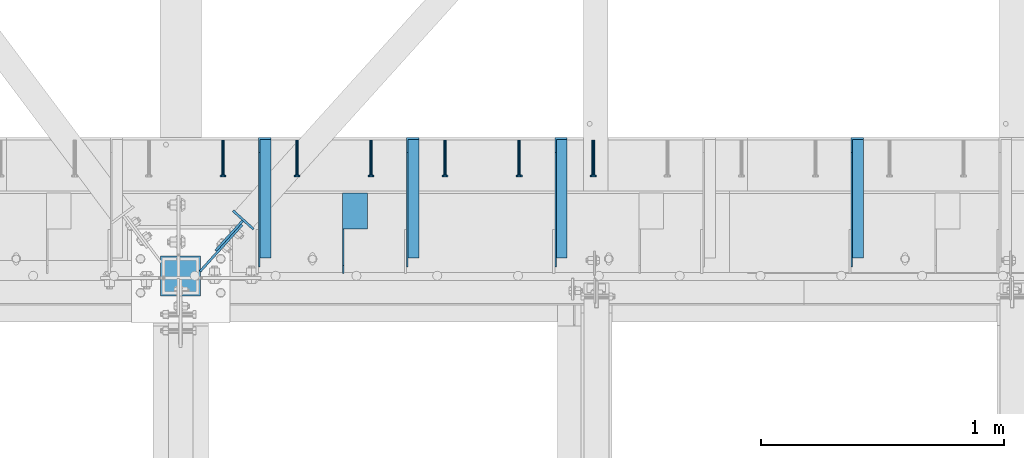
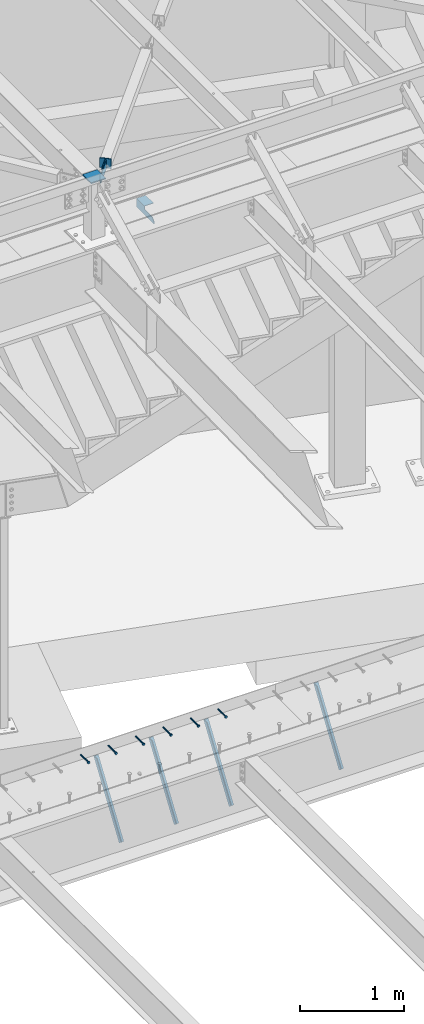
# One storey, part 1373 of 1763: 11 beams, 4 members, 10 elements without a shape of their own.
"""IFC2X3 building model written with IfcOpenShell, lengths in millimetres."""

import ifcopenshell
import ifcopenshell.guid

model = None  # the IFC model being written
_history = None  # IfcOwnerHistory: only IFC2X3 demands one
_inside = {}  # id of a spatial element -> (the spatial element, [elements in it])
_under = {}  # id of a project, library or spatial element -> (it, [spatial elements below it])
_declared = {}  # id of a project -> (the project, [libraries it declares])
_typed = {}  # id of a type object -> (the type object, [elements of that type])
_made_of = {}  # id of a material, layer set ... -> (it, [elements and type objects made of it])


def new_model(schema):
    """Start an empty IFC model of exactly this schema.

    Asked for "IFC4X3", IfcOpenShell would pick the latest addendum, in which some entities
    have other attributes; the version numbers below select the first issue.
    IFC2X3 requires an IfcOwnerHistory on every rooted entity: one is made here for all.
    """
    global model, _history
    if schema == "IFC4X3":
        model = ifcopenshell.file(schema_version=(4, 3, 0, 0))
    else:
        model = ifcopenshell.file(schema=schema)
    _inside.clear()
    _under.clear()
    _declared.clear()
    _typed.clear()
    _made_of.clear()
    _history = None
    if model.schema == "IFC2X3":
        org = make("IfcOrganization", Name="unknown")
        user = make(
            "IfcPersonAndOrganization",
            ThePerson=make("IfcPerson", FamilyName="unknown"),
            TheOrganization=org,
        )
        app = make(
            "IfcApplication",
            ApplicationDeveloper=org,
            Version="unknown",
            ApplicationFullName="unknown",
            ApplicationIdentifier="unknown",
        )
        _history = make(
            "IfcOwnerHistory",
            OwningUser=user,
            OwningApplication=app,
            ChangeAction="ADDED",
            CreationDate=0,
        )
    return model


def make(cls, **values):
    """One entity of the class cls with the attributes given. An attribute that is None is left unset."""
    return model.create_entity(
        cls, **{name: value for name, value in values.items() if value is not None}
    )


def rooted(cls, **values):
    """An entity with a GlobalId (a new one), such as an element, a storey or a relation."""
    return make(cls, GlobalId=ifcopenshell.guid.new(), OwnerHistory=_history, **values)


def si_unit(unit_type, name, prefix=None):
    """IfcSIUnit, for example si_unit("LENGTHUNIT", "METRE", prefix="MILLI")."""
    return make("IfcSIUnit", UnitType=unit_type, Prefix=prefix, Name=name)


def assignment(units):
    """IfcUnitAssignment: the units of a project."""
    return None if units is None else make("IfcUnitAssignment", Units=units)


def point(xyz):
    """IfcCartesianPoint."""
    return None if xyz is None else make("IfcCartesianPoint", Coordinates=xyz)


def direction(xyz):
    """IfcDirection."""
    return None if xyz is None else make("IfcDirection", DirectionRatios=xyz)


def frame(location, z_axis=None, x_axis=None):
    """IfcAxis2Placement3D, a coordinate frame: its origin and axes. An axis left out is left unset."""
    return make(
        "IfcAxis2Placement3D",
        Location=point(location),
        Axis=direction(z_axis),
        RefDirection=direction(x_axis),
    )


def origin_with_axes():
    """The frame at (0, 0, 0) with the z axis (0, 0, 1) and the x axis (1, 0, 0) written out."""
    return frame((0.0, 0.0, 0.0), z_axis=(0.0, 0.0, 1.0), x_axis=(1.0, 0.0, 0.0))


def place(relative_to, where):
    """IfcLocalPlacement: puts the frame where relative to a parent placement (None: the world)."""
    return make(
        "IfcLocalPlacement", PlacementRelTo=relative_to, RelativePlacement=where
    )


def context(
    kind, dimensions, precision=None, world=None, true_north=None, identifier=None
):
    """IfcGeometricRepresentationContext, for example the 3D "Model" context."""
    return make(
        "IfcGeometricRepresentationContext",
        ContextIdentifier=identifier,
        ContextType=kind,
        CoordinateSpaceDimension=dimensions,
        Precision=precision,
        WorldCoordinateSystem=world,
        TrueNorth=true_north,
    )


def subcontext(parent, identifier, kind, view, scale=None):
    """IfcGeometricRepresentationSubContext, for example "Body" below "Model"."""
    return make(
        "IfcGeometricRepresentationSubContext",
        ContextIdentifier=identifier,
        ContextType=kind,
        ParentContext=parent,
        TargetScale=scale,
        TargetView=view,
    )


def project(units=None, contexts=None):
    """IfcProject with its units and contexts."""
    return rooted(
        "IfcProject",
        Name="project",
        RepresentationContexts=contexts,
        UnitsInContext=assignment(units),
    )


def spatial(cls, under=None, at=None, **own):
    """A site, building, storey or space (cls), placed at a placement, below another one or the project."""
    s = rooted(cls, ObjectPlacement=at, **own)
    if under is not None:
        _under.setdefault(under.id(), (under, []))[1].append(s)
    return s


def faces_of(points, faces, orient=None, outer=None):
    """IfcFace entities. A face is a list of loops; a loop is a list of indices into points, from 0.

    orient and outer hold one flag for each loop. By default every Orientation is true, the
    first loop of a face is its IfcFaceOuterBound and the others are IfcFaceBound.
    """
    made = []
    for i, loops in enumerate(faces):
        bounds = []
        for j, loop in enumerate(loops):
            is_outer = j == 0 if outer is None else outer[i][j]
            bounds.append(
                make(
                    "IfcFaceOuterBound" if is_outer else "IfcFaceBound",
                    Bound=make("IfcPolyLoop", Polygon=[points[k] for k in loop]),
                    Orientation=True if orient is None else orient[i][j],
                )
            )
        made.append(make("IfcFace", Bounds=bounds))
    return made


def faceted_brep(points, faces, orient=None, outer=None, voids=None):
    """IfcFacetedBrep: a solid bounded by flat faces; with voids (closed shells), ...WithVoids."""
    shared = [point(p) for p in points]
    hull = make("IfcClosedShell", CfsFaces=faces_of(shared, faces, orient, outer))
    if voids is None:
        return make("IfcFacetedBrep", Outer=hull)
    return make(
        "IfcFacetedBrepWithVoids",
        Outer=hull,
        Voids=[
            make(cls, CfsFaces=faces_of(shared, fs, o, b)) for cls, fs, o, b in voids
        ],
    )


def shape(context_of_items, identifier, shape_type, items):
    """IfcShapeRepresentation: the items that make up one representation, for example the "Body"."""
    return make(
        "IfcShapeRepresentation",
        ContextOfItems=context_of_items,
        RepresentationIdentifier=identifier,
        RepresentationType=shape_type,
        Items=items,
    )


def material(Name=None, Category=None):
    """IfcMaterial."""
    return make("IfcMaterial", Name=Name, Category=Category)


def made_of(thing, what):
    """Note that an element or type object is made of a material, layer set ...; save() writes the relation."""
    if what is not None:
        _made_of.setdefault(what.id(), (what, []))[1].append(thing)
    return thing


def type_object(cls, material=None, **own):
    """A type object (cls), such as IfcWallType, which elements share."""
    return made_of(rooted(cls, **own), material)


def element(
    cls,
    number,
    at=None,
    inside=None,
    cuts=None,
    type_object=None,
    material=None,
    context=None,
    identifier="Body",
    shape_type=None,
    held_by="IfcProductDefinitionShape",
    body=None,
    shapes=None,
    **own,
):
    """One element of the class cls, such as IfcWall. Its Tag is "e" and its number.

    at: its placement. inside: the storey or other place that contains it. cuts: it is an
    opening in that element (IfcRelVoidsElement). A single representation is given by context,
    identifier, shape_type and body (its items); several are given by shapes. held_by: the class
    of the entity that holds the representations. save() writes the other relations.
    """
    e = rooted(cls, Tag="e%d" % number, ObjectPlacement=at, **own)
    if body is not None:
        shapes = [shape(context, identifier, shape_type, body)]
    if shapes is not None:
        e.Representation = make(held_by, Representations=shapes)
    if inside is not None:
        _inside.setdefault(inside.id(), (inside, []))[1].append(e)
    if cuts is not None:
        rooted(
            "IfcRelVoidsElement", RelatingBuildingElement=cuts, RelatedOpeningElement=e
        )
    if type_object is not None:
        _typed.setdefault(type_object.id(), (type_object, []))[1].append(e)
    return made_of(e, material)


def aggregate(whole, parts):
    """IfcRelAggregates: a whole, such as a stair, and the parts it consists of."""
    return rooted("IfcRelAggregates", RelatingObject=whole, RelatedObjects=parts)


def save(model, path):
    """Write the relations noted so far, then the file.

    IfcRelAggregates (storeys below a building ...), IfcRelContainedInSpatialStructure (elements
    in a storey), IfcRelDefinesByType, IfcRelAssociatesMaterial and IfcRelDeclares: one each for
    every whole, place, type object, material and project.
    """
    for whole, parts in _under.values():
        aggregate(whole, parts)
    for where, things in _inside.values():
        rooted(
            "IfcRelContainedInSpatialStructure",
            RelatedElements=things,
            RelatingStructure=where,
        )
    for kind, things in _typed.values():
        rooted("IfcRelDefinesByType", RelatedObjects=things, RelatingType=kind)
    for what, things in _made_of.values():
        rooted("IfcRelAssociatesMaterial", RelatedObjects=things, RelatingMaterial=what)
    for by, libraries in _declared.values():
        rooted("IfcRelDeclares", RelatingContext=by, RelatedDefinitions=libraries)
    model.write(path)


model = new_model("IFC2X3")

# Units and contexts
model_context = context("Model", 3, precision=1e-05, world=origin_with_axes())
body_context = subcontext(model_context, "Body", "Model", "MODEL_VIEW")
ifc_project = project(units=[si_unit("LENGTHUNIT", "METRE", prefix="MILLI"), si_unit("AREAUNIT", "SQUARE_METRE"), si_unit("VOLUMEUNIT", "CUBIC_METRE"), si_unit("MASSUNIT", "GRAM", prefix="KILO"), si_unit("TIMEUNIT", "SECOND"), si_unit("PLANEANGLEUNIT", "RADIAN"), si_unit("SOLIDANGLEUNIT", "STERADIAN"), si_unit("THERMODYNAMICTEMPERATUREUNIT", "DEGREE_CELSIUS"), si_unit("LUMINOUSINTENSITYUNIT", "LUMEN")], contexts=[model_context])

# Site, building, storey
site_placement = place(None, origin_with_axes())
site = spatial("IfcSite", under=ifc_project, at=site_placement, CompositionType="ELEMENT")
building_placement = place(site_placement, origin_with_axes())
building = spatial("IfcBuilding", under=site, at=building_placement, Name="Undefined", CompositionType="ELEMENT")
storey_placement = place(building_placement, origin_with_axes())
storey = spatial("IfcBuildingStorey", under=building, at=storey_placement, Name="Undefined", CompositionType="ELEMENT", Elevation=0.0)

# Assembly, beam
assembly_1_placement = place(storey_placement, origin_with_axes())
assembly_1 = element("IfcElementAssembly", 1, at=assembly_1_placement, inside=storey, Name="HEADED STUD ANCHOR", AssemblyPlace="NOTDEFINED", PredefinedType="RIGID_FRAME")
ifc_material_1 = material(Name="STEEL/A108")
beam_type_1 = type_object("IfcBeamType", PredefinedType="NOTDEFINED")
beam_1_placement = place(assembly_1_placement, frame((-29411.4466486983, 52679.6000091552, 5264.23140606069), z_axis=(0.0, 0.0, 1.0), x_axis=(0.0, -1.0, 0.0)))
beam_1 = element("IfcBeam", 2, at=beam_1_placement, type_object=beam_type_1, material=ifc_material_1, Name="HEADED STUD ANCHOR", context=body_context, shape_type="Brep", body=[
    faceted_brep([(0.0, -3.1800000667572, 5.5), (0.0, -5.5, 3.1800000667572), (141.732000000002, -5.5, 3.1800000667572), (141.732000000002, -3.1800000667572, 5.5), (0.0, -6.34999999999491, 1.45519152283669e-11), (141.732000000002, -6.34999990463257, 0.0), (0.0, -5.5, -3.1800000667572), (141.732000000002, -5.5, -3.1800000667572), (0.0, -3.1800000667572, -5.5), (141.732000000002, -3.1800000667572, -5.5), (0.0, 0.0, -6.34999990463257), (141.732000000002, 0.0, -6.34999990463257), (0.0, 3.1800000667572, -5.5), (141.732000000002, 3.1800000667572, -5.5), (0.0, 5.5, -3.1800000667572), (141.732000000002, 5.5, -3.1800000667572), (0.0, 6.34999999999491, -2.91038304567337e-11), (141.732000000002, 6.34999990463257, 0.0), (0.0, 5.5, 3.1800000667572), (141.732000000002, 5.5, 3.1800000667572), (0.0, 3.1800000667572, 5.5), (141.732000000002, 3.1800000667572, 5.5), (0.0, 0.0, 6.34999990463257), (141.732000000002, 0.0, 6.34999990463257), (144.780000000001, -10.9899997711182, 6.34999990463257), (144.780000000001, -6.34000015258789, 10.9899997711182), (144.780000000001, -12.6999998092651, 0.0), (144.780000000001, -10.9899997711182, -6.34999990463257), (144.780000000001, -6.34000015258789, -10.9899997711182), (144.780000000001, 0.0, -12.6899995803833), (144.780000000001, 6.34000015258789, -10.9899997711182), (144.780000000001, 10.9899997711182, -6.34999990463257), (144.780000000001, 12.6999998092651, 0.0), (144.780000000001, 10.9899997711182, 6.34999990463257), (144.780000000001, 6.34000015258789, 10.9899997711182), (144.780000000001, 0.0, 12.6899995803833), (152.400000000001, -10.9899997711182, 6.34999990463257), (152.400000000001, -6.34000015258789, 10.9899997711182), (152.400000000001, -12.6999998092651, 0.0), (152.400000000001, -10.9899997711182, -6.34999990463257), (152.400000000001, -6.34000015258789, -10.9899997711182), (152.400000000001, 0.0, -12.6899995803833), (152.400000000001, 6.34000015258789, -10.9899997711182), (152.400000000001, 10.9899997711182, -6.34999990463257), (152.400000000001, 12.6999998092651, 0.0), (152.400000000001, 10.9899997711182, 6.34999990463257), (152.400000000001, 6.34000015258789, 10.9899997711182), (152.400000000001, 0.0, 12.6899995803833)], [[[0, 1, 2, 3]], [[1, 4, 5, 2]], [[4, 6, 7, 5]], [[6, 8, 9, 7]], [[8, 10, 11, 9]], [[10, 12, 13, 11]], [[12, 14, 15, 13]], [[14, 16, 17, 15]], [[16, 18, 19, 17]], [[18, 20, 21, 19]], [[20, 22, 23, 21]], [[22, 0, 3, 23]], [[22, 20, 18, 16, 14, 12, 10, 8, 6, 4, 1, 0]], [[3, 2, 24, 25]], [[2, 5, 26, 24]], [[5, 7, 27, 26]], [[7, 9, 28, 27]], [[9, 11, 29, 28]], [[11, 13, 30, 29]], [[13, 15, 31, 30]], [[15, 17, 32, 31]], [[17, 19, 33, 32]], [[19, 21, 34, 33]], [[21, 23, 35, 34]], [[23, 3, 25, 35]], [[25, 24, 36, 37]], [[24, 26, 38, 36]], [[26, 27, 39, 38]], [[27, 28, 40, 39]], [[28, 29, 41, 40]], [[29, 30, 42, 41]], [[30, 31, 43, 42]], [[31, 32, 44, 43]], [[32, 33, 45, 44]], [[33, 34, 46, 45]], [[34, 35, 47, 46]], [[35, 25, 37, 47]], [[38, 39, 40, 41, 42, 43, 44, 45, 46, 47, 37, 36]]]),
])
aggregate(assembly_1, [beam_1])

assembly_2_placement = place(storey_placement, origin_with_axes())
assembly_2 = element("IfcElementAssembly", 3, at=assembly_2_placement, inside=storey, Name="HEADED STUD ANCHOR", AssemblyPlace="NOTDEFINED", PredefinedType="RIGID_FRAME")
beam_2_placement = place(assembly_2_placement, frame((-29716.2466486983, 52679.6000091552, 5264.23140606069), z_axis=(0.0, 0.0, 1.0), x_axis=(0.0, -1.0, 0.0)))
beam_2 = element("IfcBeam", 4, at=beam_2_placement, type_object=beam_type_1, material=ifc_material_1, Name="HEADED STUD ANCHOR", context=body_context, shape_type="Brep", body=[
    faceted_brep([(0.0, -3.1800000667572, 5.5), (0.0, -5.5, 3.1800000667572), (141.732000000002, -5.5, 3.1800000667572), (141.732000000002, -3.1800000667572, 5.5), (0.0, -6.34999999999491, 1.45519152283669e-11), (141.732000000002, -6.34999990463257, 0.0), (0.0, -5.5, -3.1800000667572), (141.732000000002, -5.5, -3.1800000667572), (0.0, -3.1800000667572, -5.5), (141.732000000002, -3.1800000667572, -5.5), (0.0, 0.0, -6.34999990463257), (141.732000000002, 0.0, -6.34999990463257), (0.0, 3.1800000667572, -5.5), (141.732000000002, 3.1800000667572, -5.5), (0.0, 5.5, -3.1800000667572), (141.732000000002, 5.5, -3.1800000667572), (0.0, 6.34999999999491, -2.91038304567337e-11), (141.732000000002, 6.34999990463257, 0.0), (0.0, 5.5, 3.1800000667572), (141.732000000002, 5.5, 3.1800000667572), (0.0, 3.1800000667572, 5.5), (141.732000000002, 3.1800000667572, 5.5), (0.0, 0.0, 6.34999990463257), (141.732000000002, 0.0, 6.34999990463257), (144.780000000001, -10.9899997711182, 6.34999990463257), (144.780000000001, -6.34000015258789, 10.9899997711182), (144.780000000001, -12.6999998092651, 0.0), (144.780000000001, -10.9899997711182, -6.34999990463257), (144.780000000001, -6.34000015258789, -10.9899997711182), (144.780000000001, 0.0, -12.6899995803833), (144.780000000001, 6.34000015258789, -10.9899997711182), (144.780000000001, 10.9899997711182, -6.34999990463257), (144.780000000001, 12.6999998092651, 0.0), (144.780000000001, 10.9899997711182, 6.34999990463257), (144.780000000001, 6.34000015258789, 10.9899997711182), (144.780000000001, 0.0, 12.6899995803833), (152.400000000001, -10.9899997711182, 6.34999990463257), (152.400000000001, -6.34000015258789, 10.9899997711182), (152.400000000001, -12.6999998092651, 0.0), (152.400000000001, -10.9899997711182, -6.34999990463257), (152.400000000001, -6.34000015258789, -10.9899997711182), (152.400000000001, 0.0, -12.6899995803833), (152.400000000001, 6.34000015258789, -10.9899997711182), (152.400000000001, 10.9899997711182, -6.34999990463257), (152.400000000001, 12.6999998092651, 0.0), (152.400000000001, 10.9899997711182, 6.34999990463257), (152.400000000001, 6.34000015258789, 10.9899997711182), (152.400000000001, 0.0, 12.6899995803833)], [[[0, 1, 2, 3]], [[1, 4, 5, 2]], [[4, 6, 7, 5]], [[6, 8, 9, 7]], [[8, 10, 11, 9]], [[10, 12, 13, 11]], [[12, 14, 15, 13]], [[14, 16, 17, 15]], [[16, 18, 19, 17]], [[18, 20, 21, 19]], [[20, 22, 23, 21]], [[22, 0, 3, 23]], [[22, 20, 18, 16, 14, 12, 10, 8, 6, 4, 1, 0]], [[3, 2, 24, 25]], [[2, 5, 26, 24]], [[5, 7, 27, 26]], [[7, 9, 28, 27]], [[9, 11, 29, 28]], [[11, 13, 30, 29]], [[13, 15, 31, 30]], [[15, 17, 32, 31]], [[17, 19, 33, 32]], [[19, 21, 34, 33]], [[21, 23, 35, 34]], [[23, 3, 25, 35]], [[25, 24, 36, 37]], [[24, 26, 38, 36]], [[26, 27, 39, 38]], [[27, 28, 40, 39]], [[28, 29, 41, 40]], [[29, 30, 42, 41]], [[30, 31, 43, 42]], [[31, 32, 44, 43]], [[32, 33, 45, 44]], [[33, 34, 46, 45]], [[34, 35, 47, 46]], [[35, 25, 37, 47]], [[38, 39, 40, 41, 42, 43, 44, 45, 46, 47, 37, 36]]]),
])
aggregate(assembly_2, [beam_2])

assembly_3_placement = place(storey_placement, origin_with_axes())
assembly_3 = element("IfcElementAssembly", 5, at=assembly_3_placement, inside=storey, Name="HEADED STUD ANCHOR", AssemblyPlace="NOTDEFINED", PredefinedType="RIGID_FRAME")
beam_3_placement = place(assembly_3_placement, frame((-30021.0466486983, 52679.6000091552, 5264.23140606069), z_axis=(0.0, 0.0, 1.0), x_axis=(0.0, -1.0, 0.0)))
beam_3 = element("IfcBeam", 6, at=beam_3_placement, type_object=beam_type_1, material=ifc_material_1, Name="HEADED STUD ANCHOR", context=body_context, shape_type="Brep", body=[
    faceted_brep([(0.0, -3.1800000667572, 5.5), (0.0, -5.5, 3.1800000667572), (141.732000000002, -5.5, 3.1800000667572), (141.732000000002, -3.1800000667572, 5.5), (0.0, -6.34999999999491, 1.45519152283669e-11), (141.732000000002, -6.34999990463257, 0.0), (0.0, -5.5, -3.1800000667572), (141.732000000002, -5.5, -3.1800000667572), (0.0, -3.1800000667572, -5.5), (141.732000000002, -3.1800000667572, -5.5), (0.0, 0.0, -6.34999990463257), (141.732000000002, 0.0, -6.34999990463257), (0.0, 3.1800000667572, -5.5), (141.732000000002, 3.1800000667572, -5.5), (0.0, 5.5, -3.1800000667572), (141.732000000002, 5.5, -3.1800000667572), (0.0, 6.34999999999491, -2.91038304567337e-11), (141.732000000002, 6.34999990463257, 0.0), (0.0, 5.5, 3.1800000667572), (141.732000000002, 5.5, 3.1800000667572), (0.0, 3.1800000667572, 5.5), (141.732000000002, 3.1800000667572, 5.5), (0.0, 0.0, 6.34999990463257), (141.732000000002, 0.0, 6.34999990463257), (144.780000000001, -10.9899997711182, 6.34999990463257), (144.780000000001, -6.34000015258789, 10.9899997711182), (144.780000000001, -12.6999998092651, 0.0), (144.780000000001, -10.9899997711182, -6.34999990463257), (144.780000000001, -6.34000015258789, -10.9899997711182), (144.780000000001, 0.0, -12.6899995803833), (144.780000000001, 6.34000015258789, -10.9899997711182), (144.780000000001, 10.9899997711182, -6.34999990463257), (144.780000000001, 12.6999998092651, 0.0), (144.780000000001, 10.9899997711182, 6.34999990463257), (144.780000000001, 6.34000015258789, 10.9899997711182), (144.780000000001, 0.0, 12.6899995803833), (152.400000000001, -10.9899997711182, 6.34999990463257), (152.400000000001, -6.34000015258789, 10.9899997711182), (152.400000000001, -12.6999998092651, 0.0), (152.400000000001, -10.9899997711182, -6.34999990463257), (152.400000000001, -6.34000015258789, -10.9899997711182), (152.400000000001, 0.0, -12.6899995803833), (152.400000000001, 6.34000015258789, -10.9899997711182), (152.400000000001, 10.9899997711182, -6.34999990463257), (152.400000000001, 12.6999998092651, 0.0), (152.400000000001, 10.9899997711182, 6.34999990463257), (152.400000000001, 6.34000015258789, 10.9899997711182), (152.400000000001, 0.0, 12.6899995803833)], [[[0, 1, 2, 3]], [[1, 4, 5, 2]], [[4, 6, 7, 5]], [[6, 8, 9, 7]], [[8, 10, 11, 9]], [[10, 12, 13, 11]], [[12, 14, 15, 13]], [[14, 16, 17, 15]], [[16, 18, 19, 17]], [[18, 20, 21, 19]], [[20, 22, 23, 21]], [[22, 0, 3, 23]], [[22, 20, 18, 16, 14, 12, 10, 8, 6, 4, 1, 0]], [[3, 2, 24, 25]], [[2, 5, 26, 24]], [[5, 7, 27, 26]], [[7, 9, 28, 27]], [[9, 11, 29, 28]], [[11, 13, 30, 29]], [[13, 15, 31, 30]], [[15, 17, 32, 31]], [[17, 19, 33, 32]], [[19, 21, 34, 33]], [[21, 23, 35, 34]], [[23, 3, 25, 35]], [[25, 24, 36, 37]], [[24, 26, 38, 36]], [[26, 27, 39, 38]], [[27, 28, 40, 39]], [[28, 29, 41, 40]], [[29, 30, 42, 41]], [[30, 31, 43, 42]], [[31, 32, 44, 43]], [[32, 33, 45, 44]], [[33, 34, 46, 45]], [[34, 35, 47, 46]], [[35, 25, 37, 47]], [[38, 39, 40, 41, 42, 43, 44, 45, 46, 47, 37, 36]]]),
])
aggregate(assembly_3, [beam_3])

assembly_4_placement = place(storey_placement, origin_with_axes())
assembly_4 = element("IfcElementAssembly", 7, at=assembly_4_placement, inside=storey, Name="HEADED STUD ANCHOR", AssemblyPlace="NOTDEFINED", PredefinedType="RIGID_FRAME")
beam_4_placement = place(assembly_4_placement, frame((-30325.8466486983, 52679.6000091552, 5264.23140606069), z_axis=(0.0, 0.0, 1.0), x_axis=(0.0, -1.0, 0.0)))
beam_4 = element("IfcBeam", 8, at=beam_4_placement, type_object=beam_type_1, material=ifc_material_1, Name="HEADED STUD ANCHOR", context=body_context, shape_type="Brep", body=[
    faceted_brep([(0.0, -3.1800000667572, 5.5), (0.0, -5.5, 3.1800000667572), (141.732000000002, -5.5, 3.1800000667572), (141.732000000002, -3.1800000667572, 5.5), (0.0, -6.34999999999491, 1.45519152283669e-11), (141.732000000002, -6.34999990463257, 0.0), (0.0, -5.5, -3.1800000667572), (141.732000000002, -5.5, -3.1800000667572), (0.0, -3.1800000667572, -5.5), (141.732000000002, -3.1800000667572, -5.5), (0.0, 0.0, -6.34999990463257), (141.732000000002, 0.0, -6.34999990463257), (0.0, 3.1800000667572, -5.5), (141.732000000002, 3.1800000667572, -5.5), (0.0, 5.5, -3.1800000667572), (141.732000000002, 5.5, -3.1800000667572), (0.0, 6.34999999999491, -2.91038304567337e-11), (141.732000000002, 6.34999990463257, 0.0), (0.0, 5.5, 3.1800000667572), (141.732000000002, 5.5, 3.1800000667572), (0.0, 3.1800000667572, 5.5), (141.732000000002, 3.1800000667572, 5.5), (0.0, 0.0, 6.34999990463257), (141.732000000002, 0.0, 6.34999990463257), (144.780000000001, -10.9899997711182, 6.34999990463257), (144.780000000001, -6.34000015258789, 10.9899997711182), (144.780000000001, -12.6999998092651, 0.0), (144.780000000001, -10.9899997711182, -6.34999990463257), (144.780000000001, -6.34000015258789, -10.9899997711182), (144.780000000001, 0.0, -12.6899995803833), (144.780000000001, 6.34000015258789, -10.9899997711182), (144.780000000001, 10.9899997711182, -6.34999990463257), (144.780000000001, 12.6999998092651, 0.0), (144.780000000001, 10.9899997711182, 6.34999990463257), (144.780000000001, 6.34000015258789, 10.9899997711182), (144.780000000001, 0.0, 12.6899995803833), (152.400000000001, -10.9899997711182, 6.34999990463257), (152.400000000001, -6.34000015258789, 10.9899997711182), (152.400000000001, -12.6999998092651, 0.0), (152.400000000001, -10.9899997711182, -6.34999990463257), (152.400000000001, -6.34000015258789, -10.9899997711182), (152.400000000001, 0.0, -12.6899995803833), (152.400000000001, 6.34000015258789, -10.9899997711182), (152.400000000001, 10.9899997711182, -6.34999990463257), (152.400000000001, 12.6999998092651, 0.0), (152.400000000001, 10.9899997711182, 6.34999990463257), (152.400000000001, 6.34000015258789, 10.9899997711182), (152.400000000001, 0.0, 12.6899995803833)], [[[0, 1, 2, 3]], [[1, 4, 5, 2]], [[4, 6, 7, 5]], [[6, 8, 9, 7]], [[8, 10, 11, 9]], [[10, 12, 13, 11]], [[12, 14, 15, 13]], [[14, 16, 17, 15]], [[16, 18, 19, 17]], [[18, 20, 21, 19]], [[20, 22, 23, 21]], [[22, 0, 3, 23]], [[22, 20, 18, 16, 14, 12, 10, 8, 6, 4, 1, 0]], [[3, 2, 24, 25]], [[2, 5, 26, 24]], [[5, 7, 27, 26]], [[7, 9, 28, 27]], [[9, 11, 29, 28]], [[11, 13, 30, 29]], [[13, 15, 31, 30]], [[15, 17, 32, 31]], [[17, 19, 33, 32]], [[19, 21, 34, 33]], [[21, 23, 35, 34]], [[23, 3, 25, 35]], [[25, 24, 36, 37]], [[24, 26, 38, 36]], [[26, 27, 39, 38]], [[27, 28, 40, 39]], [[28, 29, 41, 40]], [[29, 30, 42, 41]], [[30, 31, 43, 42]], [[31, 32, 44, 43]], [[32, 33, 45, 44]], [[33, 34, 46, 45]], [[34, 35, 47, 46]], [[35, 25, 37, 47]], [[38, 39, 40, 41, 42, 43, 44, 45, 46, 47, 37, 36]]]),
])
aggregate(assembly_4, [beam_4])

assembly_5_placement = place(storey_placement, origin_with_axes())
assembly_5 = element("IfcElementAssembly", 9, at=assembly_5_placement, inside=storey, Name="HEADED STUD ANCHOR", AssemblyPlace="NOTDEFINED", PredefinedType="RIGID_FRAME")
beam_5_placement = place(assembly_5_placement, frame((-30630.6466486983, 52679.6000091552, 5264.23140606069), z_axis=(0.0, 0.0, 1.0), x_axis=(0.0, -1.0, 0.0)))
beam_5 = element("IfcBeam", 10, at=beam_5_placement, type_object=beam_type_1, material=ifc_material_1, Name="HEADED STUD ANCHOR", context=body_context, shape_type="Brep", body=[
    faceted_brep([(0.0, -3.1800000667572, 5.5), (0.0, -5.5, 3.1800000667572), (141.732000000002, -5.5, 3.1800000667572), (141.732000000002, -3.1800000667572, 5.5), (0.0, -6.34999999999491, 1.45519152283669e-11), (141.732000000002, -6.34999990463257, 0.0), (0.0, -5.5, -3.1800000667572), (141.732000000002, -5.5, -3.1800000667572), (0.0, -3.1800000667572, -5.5), (141.732000000002, -3.1800000667572, -5.5), (0.0, 0.0, -6.34999990463257), (141.732000000002, 0.0, -6.34999990463257), (0.0, 3.1800000667572, -5.5), (141.732000000002, 3.1800000667572, -5.5), (0.0, 5.5, -3.1800000667572), (141.732000000002, 5.5, -3.1800000667572), (0.0, 6.34999999999491, -2.91038304567337e-11), (141.732000000002, 6.34999990463257, 0.0), (0.0, 5.5, 3.1800000667572), (141.732000000002, 5.5, 3.1800000667572), (0.0, 3.1800000667572, 5.5), (141.732000000002, 3.1800000667572, 5.5), (0.0, 0.0, 6.34999990463257), (141.732000000002, 0.0, 6.34999990463257), (144.780000000001, -10.9899997711182, 6.34999990463257), (144.780000000001, -6.34000015258789, 10.9899997711182), (144.780000000001, -12.6999998092651, 0.0), (144.780000000001, -10.9899997711182, -6.34999990463257), (144.780000000001, -6.34000015258789, -10.9899997711182), (144.780000000001, 0.0, -12.6899995803833), (144.780000000001, 6.34000015258789, -10.9899997711182), (144.780000000001, 10.9899997711182, -6.34999990463257), (144.780000000001, 12.6999998092651, 0.0), (144.780000000001, 10.9899997711182, 6.34999990463257), (144.780000000001, 6.34000015258789, 10.9899997711182), (144.780000000001, 0.0, 12.6899995803833), (152.400000000001, -10.9899997711182, 6.34999990463257), (152.400000000001, -6.34000015258789, 10.9899997711182), (152.400000000001, -12.6999998092651, 0.0), (152.400000000001, -10.9899997711182, -6.34999990463257), (152.400000000001, -6.34000015258789, -10.9899997711182), (152.400000000001, 0.0, -12.6899995803833), (152.400000000001, 6.34000015258789, -10.9899997711182), (152.400000000001, 10.9899997711182, -6.34999990463257), (152.400000000001, 12.6999998092651, 0.0), (152.400000000001, 10.9899997711182, 6.34999990463257), (152.400000000001, 6.34000015258789, 10.9899997711182), (152.400000000001, 0.0, 12.6899995803833)], [[[0, 1, 2, 3]], [[1, 4, 5, 2]], [[4, 6, 7, 5]], [[6, 8, 9, 7]], [[8, 10, 11, 9]], [[10, 12, 13, 11]], [[12, 14, 15, 13]], [[14, 16, 17, 15]], [[16, 18, 19, 17]], [[18, 20, 21, 19]], [[20, 22, 23, 21]], [[22, 0, 3, 23]], [[22, 20, 18, 16, 14, 12, 10, 8, 6, 4, 1, 0]], [[3, 2, 24, 25]], [[2, 5, 26, 24]], [[5, 7, 27, 26]], [[7, 9, 28, 27]], [[9, 11, 29, 28]], [[11, 13, 30, 29]], [[13, 15, 31, 30]], [[15, 17, 32, 31]], [[17, 19, 33, 32]], [[19, 21, 34, 33]], [[21, 23, 35, 34]], [[23, 3, 25, 35]], [[25, 24, 36, 37]], [[24, 26, 38, 36]], [[26, 27, 39, 38]], [[27, 28, 40, 39]], [[28, 29, 41, 40]], [[29, 30, 42, 41]], [[30, 31, 43, 42]], [[31, 32, 44, 43]], [[32, 33, 45, 44]], [[33, 34, 46, 45]], [[34, 35, 47, 46]], [[35, 25, 37, 47]], [[38, 39, 40, 41, 42, 43, 44, 45, 46, 47, 37, 36]]]),
])
aggregate(assembly_5, [beam_5])

assembly_6_placement = place(storey_placement, origin_with_axes())
assembly_6 = element("IfcElementAssembly", 11, at=assembly_6_placement, inside=storey, Name="HEADED STUD ANCHOR", AssemblyPlace="NOTDEFINED", PredefinedType="RIGID_FRAME")
beam_6_placement = place(assembly_6_placement, frame((-30935.4466486983, 52679.6000091552, 5264.23140606069), z_axis=(0.0, 0.0, 1.0), x_axis=(0.0, -1.0, 0.0)))
beam_6 = element("IfcBeam", 12, at=beam_6_placement, type_object=beam_type_1, material=ifc_material_1, Name="HEADED STUD ANCHOR", context=body_context, shape_type="Brep", body=[
    faceted_brep([(0.0, -3.1800000667572, 5.5), (0.0, -5.5, 3.1800000667572), (141.732000000002, -5.5, 3.1800000667572), (141.732000000002, -3.1800000667572, 5.5), (0.0, -6.34999999999491, 1.45519152283669e-11), (141.732000000002, -6.34999990463257, 0.0), (0.0, -5.5, -3.1800000667572), (141.732000000002, -5.5, -3.1800000667572), (0.0, -3.1800000667572, -5.5), (141.732000000002, -3.1800000667572, -5.5), (0.0, 0.0, -6.34999990463257), (141.732000000002, 0.0, -6.34999990463257), (0.0, 3.1800000667572, -5.5), (141.732000000002, 3.1800000667572, -5.5), (0.0, 5.5, -3.1800000667572), (141.732000000002, 5.5, -3.1800000667572), (0.0, 6.34999999999491, -2.91038304567337e-11), (141.732000000002, 6.34999990463257, 0.0), (0.0, 5.5, 3.1800000667572), (141.732000000002, 5.5, 3.1800000667572), (0.0, 3.1800000667572, 5.5), (141.732000000002, 3.1800000667572, 5.5), (0.0, 0.0, 6.34999990463257), (141.732000000002, 0.0, 6.34999990463257), (144.780000000001, -10.9899997711182, 6.34999990463257), (144.780000000001, -6.34000015258789, 10.9899997711182), (144.780000000001, -12.6999998092651, 0.0), (144.780000000001, -10.9899997711182, -6.34999990463257), (144.780000000001, -6.34000015258789, -10.9899997711182), (144.780000000001, 0.0, -12.6899995803833), (144.780000000001, 6.34000015258789, -10.9899997711182), (144.780000000001, 10.9899997711182, -6.34999990463257), (144.780000000001, 12.6999998092651, 0.0), (144.780000000001, 10.9899997711182, 6.34999990463257), (144.780000000001, 6.34000015258789, 10.9899997711182), (144.780000000001, 0.0, 12.6899995803833), (152.400000000001, -10.9899997711182, 6.34999990463257), (152.400000000001, -6.34000015258789, 10.9899997711182), (152.400000000001, -12.6999998092651, 0.0), (152.400000000001, -10.9899997711182, -6.34999990463257), (152.400000000001, -6.34000015258789, -10.9899997711182), (152.400000000001, 0.0, -12.6899995803833), (152.400000000001, 6.34000015258789, -10.9899997711182), (152.400000000001, 10.9899997711182, -6.34999990463257), (152.400000000001, 12.6999998092651, 0.0), (152.400000000001, 10.9899997711182, 6.34999990463257), (152.400000000001, 6.34000015258789, 10.9899997711182), (152.400000000001, 0.0, 12.6899995803833)], [[[0, 1, 2, 3]], [[1, 4, 5, 2]], [[4, 6, 7, 5]], [[6, 8, 9, 7]], [[8, 10, 11, 9]], [[10, 12, 13, 11]], [[12, 14, 15, 13]], [[14, 16, 17, 15]], [[16, 18, 19, 17]], [[18, 20, 21, 19]], [[20, 22, 23, 21]], [[22, 0, 3, 23]], [[22, 20, 18, 16, 14, 12, 10, 8, 6, 4, 1, 0]], [[3, 2, 24, 25]], [[2, 5, 26, 24]], [[5, 7, 27, 26]], [[7, 9, 28, 27]], [[9, 11, 29, 28]], [[11, 13, 30, 29]], [[13, 15, 31, 30]], [[15, 17, 32, 31]], [[17, 19, 33, 32]], [[19, 21, 34, 33]], [[21, 23, 35, 34]], [[23, 3, 25, 35]], [[25, 24, 36, 37]], [[24, 26, 38, 36]], [[26, 27, 39, 38]], [[27, 28, 40, 39]], [[28, 29, 41, 40]], [[29, 30, 42, 41]], [[30, 31, 43, 42]], [[31, 32, 44, 43]], [[32, 33, 45, 44]], [[33, 34, 46, 45]], [[34, 35, 47, 46]], [[35, 25, 37, 47]], [[38, 39, 40, 41, 42, 43, 44, 45, 46, 47, 37, 36]]]),
])
aggregate(assembly_6, [beam_6])

# Assembly, members
assembly_7_placement = place(storey_placement, origin_with_axes())
assembly_7 = element("IfcElementAssembly", 13, at=assembly_7_placement, inside=storey, Name="BEAM", AssemblyPlace="NOTDEFINED", PredefinedType="RIGID_FRAME")
ifc_material_2 = material(Name="STEEL/A36")
member_type = type_object("IfcMemberType", Name="L2X2X1/4", PredefinedType="NOTDEFINED")
member_1_placement = place(assembly_7_placement, frame((-28325.0370109278, 52177.7789126344, 4484.66874800095), z_axis=(0.0, -0.827940419190063, 0.560816068128742), x_axis=(0.0, 0.560816068128741, 0.827940419190064)))
member_1 = element("IfcMember", 14, at=member_1_placement, type_object=member_type, material=ifc_material_2, Name="ANGLE", ObjectType="L2X2X1/4", context=body_context, shape_type="Brep", body=[
    faceted_brep([(-1.45519152283669e-11, 25.4000000000015, -25.3999999999869), (1.45519152283669e-11, 25.4000000000015, 25.3999999999796), (839.899233991324, 25.4000000000015, 25.3999999994412), (874.309265921926, 25.4000000000015, -25.4000000006854), (1.45519152283669e-11, 19.0499999999993, 25.3999999999796), (839.899233991324, 19.0499999999993, 25.3999999994412), (-7.27595761418343e-12, 19.0499999999993, -19.0499999999956), (870.0080119306, 19.0499999999993, -19.0500000006723), (-7.27595761418343e-12, -25.4000000000015, -19.0499999999956), (870.0080119306, -25.4000000000015, -19.0500000006723), (-1.45519152283669e-11, -25.4000000000015, -25.3999999999869), (874.309265921926, -25.4000000000015, -25.4000000006854)], [[[0, 1, 2, 3]], [[1, 4, 5, 2]], [[4, 6, 7, 5]], [[6, 8, 9, 7]], [[8, 10, 11, 9]], [[10, 0, 3, 11]], [[5, 7, 9, 11, 3, 2]], [[10, 8, 6, 4, 1, 0]]]),
])
member_2_placement = place(assembly_7_placement, frame((-29544.2370109278, 52177.7789126344, 4484.66874800095), z_axis=(0.0, -0.827940419190063, 0.560816068128742), x_axis=(0.0, 0.560816068128741, 0.827940419190064)))
member_2 = element("IfcMember", 15, at=member_2_placement, type_object=member_type, material=ifc_material_2, Name="ANGLE", ObjectType="L2X2X1/4", context=body_context, shape_type="Brep", body=[
    faceted_brep([(-1.45519152283669e-11, 25.4000000000015, -25.3999999999869), (1.45519152283669e-11, 25.4000000000015, 25.3999999999796), (839.899233991324, 25.4000000000015, 25.3999999994412), (874.309265921926, 25.4000000000015, -25.4000000006854), (1.45519152283669e-11, 19.0499999999993, 25.3999999999796), (839.899233991324, 19.0499999999993, 25.3999999994412), (-7.27595761418343e-12, 19.0499999999993, -19.0499999999956), (870.0080119306, 19.0499999999993, -19.0500000006723), (-7.27595761418343e-12, -25.4000000000015, -19.0499999999956), (870.0080119306, -25.4000000000015, -19.0500000006723), (-1.45519152283669e-11, -25.4000000000015, -25.3999999999869), (874.309265921926, -25.4000000000015, -25.4000000006854)], [[[0, 1, 2, 3]], [[1, 4, 5, 2]], [[4, 6, 7, 5]], [[6, 8, 9, 7]], [[8, 10, 11, 9]], [[10, 0, 3, 11]], [[5, 7, 9, 11, 3, 2]], [[10, 8, 6, 4, 1, 0]]]),
])
member_3_placement = place(assembly_7_placement, frame((-30153.8370109278, 52177.7789126344, 4484.66874800095), z_axis=(0.0, -0.827940419190063, 0.560816068128742), x_axis=(0.0, 0.560816068128741, 0.827940419190064)))
member_3 = element("IfcMember", 16, at=member_3_placement, type_object=member_type, material=ifc_material_2, Name="ANGLE", ObjectType="L2X2X1/4", context=body_context, shape_type="Brep", body=[
    faceted_brep([(-1.45519152283669e-11, 25.4000000000015, -25.3999999999869), (1.45519152283669e-11, 25.4000000000015, 25.3999999999796), (839.899233991324, 25.4000000000015, 25.3999999994412), (874.309265921926, 25.4000000000015, -25.4000000006854), (1.45519152283669e-11, 19.0499999999993, 25.3999999999796), (839.899233991324, 19.0499999999993, 25.3999999994412), (-7.27595761418343e-12, 19.0499999999993, -19.0499999999956), (870.0080119306, 19.0499999999993, -19.0500000006723), (-7.27595761418343e-12, -25.4000000000015, -19.0499999999956), (870.0080119306, -25.4000000000015, -19.0500000006723), (-1.45519152283669e-11, -25.4000000000015, -25.3999999999869), (874.309265921926, -25.4000000000015, -25.4000000006854)], [[[0, 1, 2, 3]], [[1, 4, 5, 2]], [[4, 6, 7, 5]], [[6, 8, 9, 7]], [[8, 10, 11, 9]], [[10, 0, 3, 11]], [[5, 7, 9, 11, 3, 2]], [[10, 8, 6, 4, 1, 0]]]),
])
member_4_placement = place(assembly_7_placement, frame((-30763.4370109278, 52177.7789126344, 4484.66874800095), z_axis=(0.0, -0.827940419190063, 0.560816068128742), x_axis=(0.0, 0.560816068128741, 0.827940419190064)))
member_4 = element("IfcMember", 17, at=member_4_placement, type_object=member_type, material=ifc_material_2, Name="ANGLE", ObjectType="L2X2X1/4", context=body_context, shape_type="Brep", body=[
    faceted_brep([(-1.45519152283669e-11, 25.4000000000015, -25.3999999999869), (1.45519152283669e-11, 25.4000000000015, 25.3999999999796), (839.899233991324, 25.4000000000015, 25.3999999994412), (874.309265921926, 25.4000000000015, -25.4000000006854), (1.45519152283669e-11, 19.0499999999993, 25.3999999999796), (839.899233991324, 19.0499999999993, 25.3999999994412), (-7.27595761418343e-12, 19.0499999999993, -19.0499999999956), (870.0080119306, 19.0499999999993, -19.0500000006723), (-7.27595761418343e-12, -25.4000000000015, -19.0499999999956), (870.0080119306, -25.4000000000015, -19.0500000006723), (-1.45519152283669e-11, -25.4000000000015, -25.3999999999869), (874.309265921926, -25.4000000000015, -25.4000000006854)], [[[0, 1, 2, 3]], [[1, 4, 5, 2]], [[4, 6, 7, 5]], [[6, 8, 9, 7]], [[8, 10, 11, 9]], [[10, 0, 3, 11]], [[5, 7, 9, 11, 3, 2]], [[10, 8, 6, 4, 1, 0]]]),
])
aggregate(assembly_7, [member_1, member_2, member_3, member_4])

# Assembly, beam
assembly_8_placement = place(storey_placement, origin_with_axes())
assembly_8 = element("IfcElementAssembly", 18, at=assembly_8_placement, inside=storey, Name="BEAM", AssemblyPlace="NOTDEFINED", PredefinedType="RIGID_FRAME")
beam_type_2 = type_object("IfcBeamType", Name="L4X4X1/4", PredefinedType="NOTDEFINED")
beam_7_placement = place(assembly_8_placement, frame((-30392.1247736984, 52462.1124819023, 11696.6999917654), z_axis=(0.0, 0.0, -1.0), x_axis=(0.0, -1.0, 0.0)))
beam_7 = element("IfcBeam", 19, at=beam_7_placement, type_object=beam_type_2, material=ifc_material_2, Name="BRACE", ObjectType="L4X4X1/4", context=body_context, shape_type="Brep", body=[
    faceted_brep([(148.43173432786, 44.4500000000007, -44.4500000000007), (148.431790430077, -50.7999999999993, -44.4500000000007), (148.431790785675, -50.7999999999993, -50.7999999999993), (148.43173094331, 50.7999999999993, -50.7999999999993), (148.431728809323, 50.7999999999993, -12.6999970794623), (148.431732549492, 44.4500000000007, -12.6999970794623), (299.243731689443, 50.7999999999993, -12.7000043904281), (299.243731689443, 44.4499999999971, -12.7000043904281), (2.11002770811319e-10, -50.8000000000357, -50.799999999952), (1.96450855582952e-10, -50.8000000000338, -44.4499999999534), (-2.18278728425503e-11, 44.4500000000007, -44.450000000048), (-1.81898940354586e-10, 44.4500000000371, 50.7999999999374), (-1.96450855582952e-10, 50.8000000000393, 50.7999999999374), (-3.63797880709171e-11, 50.8000000000011, -50.8000000000538), (330.993731689443, 44.4500000000007, 50.7999999999993), (330.993731689443, 50.7999999999993, 50.7999999999993), (330.993731689443, 44.4500000000007, 19.050000000012), (330.993731689443, 50.7999999999993, 19.050000000012)], [[[0, 1, 2, 3, 4, 5]], [[5, 4, 6, 7]], [[8, 9, 10, 11, 12, 13]], [[12, 11, 14, 15]], [[15, 14, 16, 17]], [[16, 7, 6, 17]], [[4, 3, 13, 12, 15, 17, 6]], [[8, 13, 3, 2]], [[9, 8, 2, 1]], [[10, 9, 1, 0]], [[14, 11, 10, 0, 5, 7, 16]]]),
])
aggregate(assembly_8, [beam_7])

assembly_9_placement = place(storey_placement, origin_with_axes())
assembly_9 = element("IfcElementAssembly", 20, at=assembly_9_placement, inside=storey, Name="COLUMN", AssemblyPlace="NOTDEFINED", PredefinedType="RIGID_FRAME")
beam_type_3 = type_object("IfcBeamType", PredefinedType="NOTDEFINED")
beam_8_placement = place(assembly_9_placement, frame((-30942.9535582615, 52234.7747741451, 12422.1875), z_axis=(-0.669524421073345, -0.742790044081369, 0.0), x_axis=(0.0, 0.0, -1.0)))
beam_8 = element("IfcBeam", 21, at=beam_8_placement, type_object=beam_type_3, material=ifc_material_2, Name="PLATE", context=body_context, shape_type="Brep", body=[
    faceted_brep([(0.0, 4.76249999984611, -129.381000000176), (0.0, 4.76250000012988, 129.381000000161), (101.599999999999, 4.76250000012988, 129.381000000161), (101.599999999999, 4.76249999984611, -129.381000000176), (0.0, -4.76249999985703, 129.381000000147), (101.599999999999, -4.76249999985703, 129.381000000147), (0.0, -4.76250000014443, -129.38100000019), (101.599999999999, -4.76250000014443, -129.38100000019)], [[[0, 1, 2, 3]], [[1, 4, 5, 2]], [[4, 6, 7, 5]], [[6, 0, 3, 7]], [[5, 7, 3, 2]], [[6, 4, 1, 0]]]),
])

# Assembly, beams
assembly_10_placement = place(storey_placement, origin_with_axes())
assembly_10 = element("IfcElementAssembly", 22, at=assembly_10_placement, inside=storey, Name="H. BRACE", AssemblyPlace="NOTDEFINED", PredefinedType="RIGID_FRAME")
beam_9_placement = place(assembly_10_placement, frame((-30909.8216953177, 52285.7587449816, 12422.1875), z_axis=(-0.669524421073345, -0.742790044081369, 0.0), x_axis=(0.0, 0.0, -1.0)))
beam_9 = element("IfcBeam", 23, at=beam_9_placement, type_object=beam_type_3, material=ifc_material_2, Name="PLATE", context=body_context, shape_type="Brep", body=[
    faceted_brep([(0.0, 4.7625000001417, -82.5500000001048), (0.0, 4.76249999986885, 82.5500000001339), (101.599999999999, 4.76249999986885, 82.5500000001339), (101.599999999999, 4.7625000001417, -82.5500000001048), (0.0, -4.76250000014352, 82.5500000001193), (101.599999999999, -4.76250000014352, 82.5500000001193), (0.0, -4.76249999987067, -82.5500000001193), (101.599999999999, -4.76249999987067, -82.5500000001193)], [[[0, 1, 2, 3]], [[1, 4, 5, 2]], [[4, 6, 7, 5]], [[6, 0, 3, 7]], [[5, 7, 3, 2]], [[6, 4, 1, 0]]]),
])
beam_type_4 = type_object("IfcBeamType", PredefinedType="NOTDEFINED")
beam_10_placement = place(assembly_10_placement, frame((-30851.3638443034, 52350.6136007054, 12428.5375), z_axis=(0.742790044081369, -0.669524421073345, 0.0), x_axis=(0.0, 0.0, -1.0)))
beam_10 = element("IfcBeam", 24, at=beam_10_placement, type_object=beam_type_4, material=ifc_material_2, Name="PLATE", context=body_context, shape_type="Brep", body=[
    faceted_brep([(0.0, 4.76249999989523, -57.1500000001702), (0.0, 4.76250000014261, 57.1500000001565), (114.299999999999, 4.76250000014261, 57.1500000001565), (114.299999999999, 4.76249999989523, -57.1500000001702), (0.0, -4.76249999988067, 57.1500000001784), (114.299999999999, -4.76249999988067, 57.1500000001784), (0.0, -4.76250000012806, -57.150000000152), (114.299999999999, -4.76250000012806, -57.150000000152)], [[[0, 1, 2, 3]], [[1, 4, 5, 2]], [[4, 6, 7, 5]], [[6, 0, 3, 7]], [[5, 7, 3, 2]], [[6, 4, 1, 0]]]),
])
aggregate(assembly_10, [beam_10, beam_9])

# Beam
beam_type_5 = type_object("IfcBeamType", PredefinedType="NOTDEFINED")
beam_11_placement = place(assembly_9_placement, frame((-31109.3146174535, 52038.2500137365, 12439.65), z_axis=(1.0, 0.0, 0.0), x_axis=(0.0, 1.0, 0.0)))
beam_11 = element("IfcBeam", 25, at=beam_11_placement, type_object=beam_type_5, material=ifc_material_2, Name="PLATE", context=body_context, shape_type="Brep", body=[
    faceted_brep([(0.0, 6.35000000000036, -82.5499999999993), (0.0, 6.35000000000036, 82.5499999999993), (165.099999999991, 6.35000000000036, 82.5499999999993), (165.099999999991, 6.35000000000036, -82.5499999999993), (0.0, -6.35000000000036, 82.5499999999993), (165.099999999991, -6.35000000000036, 82.5499999999993), (0.0, -6.35000000000036, -82.5499999999993), (165.099999999991, -6.35000000000036, -82.5499999999993)], [[[0, 1, 2, 3]], [[1, 4, 5, 2]], [[4, 6, 7, 5]], [[6, 0, 3, 7]], [[5, 7, 3, 2]], [[6, 4, 1, 0]]]),
])

aggregate(assembly_9, [beam_8, beam_11])

save(model, "model.ifc")
